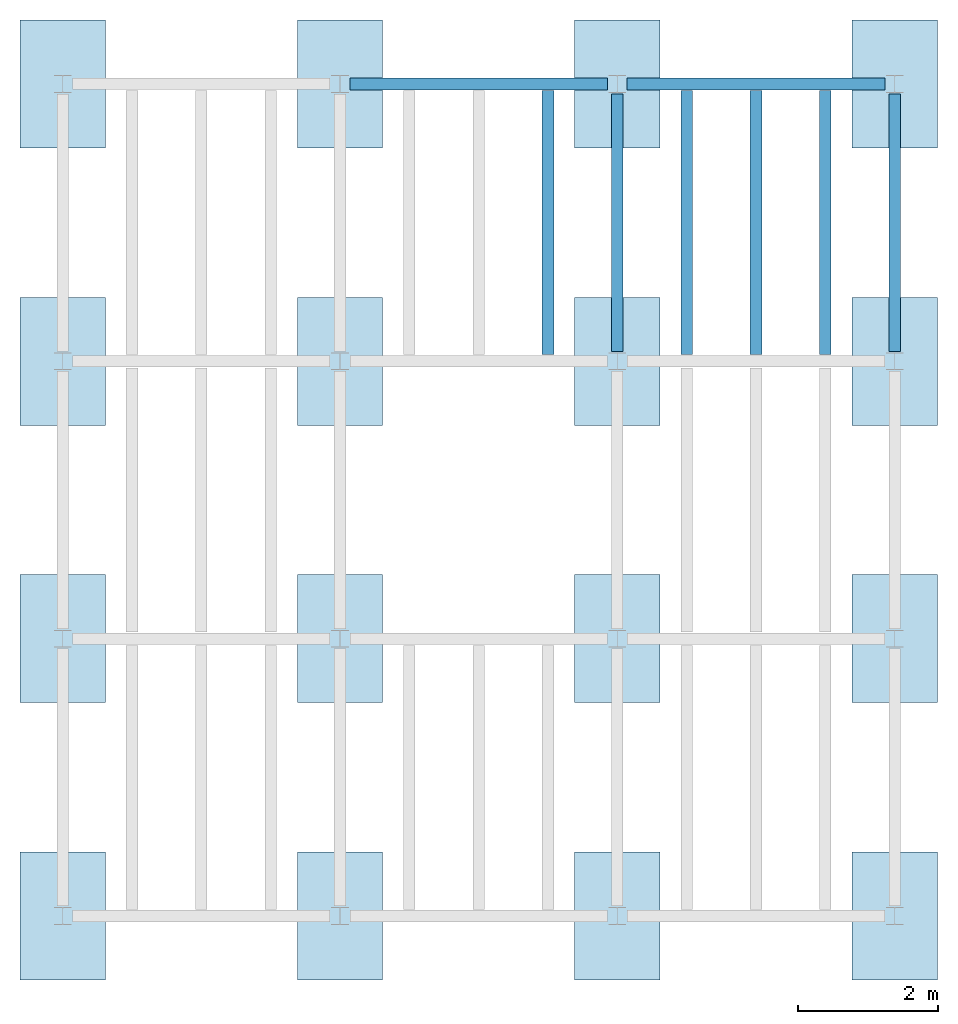
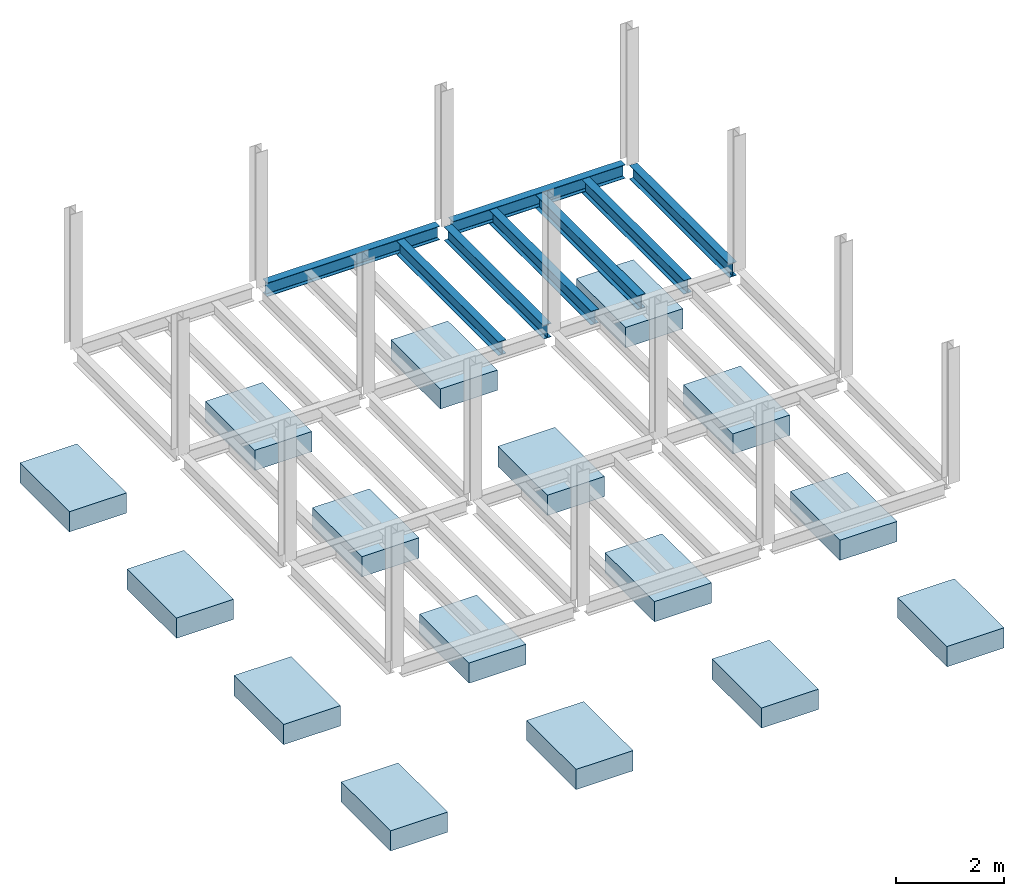
# One storey, part 2 of 2: 16 slabs, 8 beams, 2 elements without a shape of their own.
"""IFC4 building model written with IfcOpenShell, lengths in feet."""

from ifc_helpers import new_model, entity, si_unit, converted_unit, derived_unit, direction, frame, origin, place, context, subcontext, project, spatial, line, arc, indexed_curve, outline, extrude, source, transform, mapped, material, type_object, type_shapes, element, aggregate, save


model = new_model("IFC4")

# Units and contexts
model_context = context("Model", 3, precision=0.0001, world=origin(), true_north=direction((6.123233995736766e-17, 1.0)))
plan_context = context("Plan", 3, precision=0.0001, world=origin(), true_north=direction((6.123233995736766e-17, 1.0)))
body_context = subcontext(model_context, "Body", "Model", "MODEL_VIEW")
ifc_project = project(units=[converted_unit("LENGTHUNIT", "FOOT", entity("IfcLengthMeasure", 0.3048), si_unit("LENGTHUNIT", "METRE"), dimensions=[1, 0, 0, 0, 0, 0, 0]), converted_unit("AREAUNIT", "SQUARE FOOT", entity("IfcAreaMeasure", 0.09290304), si_unit("AREAUNIT", "SQUARE_METRE"), dimensions=[2, 0, 0, 0, 0, 0, 0]), converted_unit("PLANEANGLEUNIT", "DEGREE", entity("IfcPlaneAngleMeasure", 0.017453292519943278), si_unit("PLANEANGLEUNIT", "RADIAN"), dimensions=[0, 0, 0, 0, 0, 0, 0]), converted_unit("VOLUMEUNIT", "CUBIC FOOT", entity("IfcVolumeMeasure", 0.028316846592000004), si_unit("VOLUMEUNIT", "CUBIC_METRE"), dimensions=[3, 0, 0, 0, 0, 0, 0]), si_unit("PRESSUREUNIT", "PASCAL"), derived_unit("MASSDENSITYUNIT", [(si_unit("MASSUNIT", "GRAM", prefix="KILO"), 1), (si_unit("LENGTHUNIT", "METRE"), -3)]), derived_unit("VAPORPERMEABILITYUNIT", [(si_unit("LENGTHUNIT", "METRE"), -1), (si_unit("TIMEUNIT", "SECOND"), 1)]), derived_unit("USERDEFINED", [(si_unit("MASSUNIT", "GRAM", prefix="KILO"), 1), (si_unit("LENGTHUNIT", "METRE"), 3), (si_unit("TIMEUNIT", "SECOND"), -3), (si_unit("ELECTRICCURRENTUNIT", "AMPERE"), -2)]), derived_unit("MODULUSOFELASTICITYUNIT", [(si_unit("MASSUNIT", "GRAM", prefix="KILO"), 1), (si_unit("LENGTHUNIT", "METRE"), -1), (si_unit("TIMEUNIT", "SECOND"), -2)]), derived_unit("THERMALEXPANSIONCOEFFICIENTUNIT", [(si_unit("THERMODYNAMICTEMPERATUREUNIT", "KELVIN"), -1)]), derived_unit("SPECIFICHEATCAPACITYUNIT", [(si_unit("TIMEUNIT", "SECOND"), -2), (si_unit("THERMODYNAMICTEMPERATUREUNIT", "KELVIN"), -1), (si_unit("LENGTHUNIT", "METRE"), 2)]), derived_unit("THERMALCONDUCTANCEUNIT", [(si_unit("MASSUNIT", "GRAM", prefix="KILO"), 1), (si_unit("TIMEUNIT", "SECOND"), -3), (si_unit("THERMODYNAMICTEMPERATUREUNIT", "KELVIN"), -1), (si_unit("LENGTHUNIT", "METRE"), 1)])], contexts=[model_context, plan_context])

# Site, building, storey
site_placement = place(None, origin())
site = spatial("IfcSite", under=ifc_project, at=site_placement, CompositionType="ELEMENT")
building_placement = place(site_placement, origin())
building = spatial("IfcBuilding", under=site, at=building_placement, CompositionType="ELEMENT")
storey_placement = place(building_placement, frame((0.0, 0.0, 9.875000000001839)))
storey = spatial("IfcBuildingStorey", under=building, at=storey_placement, Name="STR 02", CompositionType="ELEMENT", Elevation=9.875000000001839)

# Beams
ifc_material_1 = material(Name="Steel ASTM A992", Category="Metal")
beam_type_1 = type_object("IfcBeamType", Name="W12X26", PredefinedType="JOIST", material=ifc_material_1)
shared_shape_1 = source(origin(), body_context, "Body", "SweptSolid", [
    extrude(outline(indexed_curve([(-0.27041666666666714, -0.47666666666666574), (-0.27041666666666714, -0.5083333333333351), (0.2704166666666669, -0.5083333333333351), (0.2704166666666669, -0.47666666666666574), (0.03458333333333309, -0.47666666666666574), (0.016905663803669493, -0.46934433619632937), (0.009583333333333202, -0.4516666666666659), (0.0095833333333332, 0.45166666666666705), (0.01690566380366948, 0.4693443361963307), (0.03458333333333325, 0.4766666666666671), (0.2704166666666669, 0.4766666666666671), (0.2704166666666669, 0.5083333333333312), (-0.2704166666666655, 0.5083333333333312), (-0.2704166666666655, 0.4766666666666671), (-0.034583333333333514, 0.47666666666666707), (-0.016905663803669865, 0.46934433619633054), (-0.009583333333333737, 0.45166666666666694), (-0.009583333333333735, -0.4516666666666658), (-0.01690566380367013, -0.4693443361963295), (-0.03458333333333368, -0.47666666666666574)], segments=[line(1, 2, 3, 4, 5), arc(5, 6, 7), line(7, 8), arc(8, 9, 10), line(10, 11, 12, 13, 14, 15), arc(15, 16, 17), line(17, 18), arc(18, 19, 20), line(20, 1)], self_intersect=False)), frame((-6.226706036745409, 0.0, 0.0), z_axis=(-1.0, 0.0, 0.0), x_axis=(0.0, -1.0, 0.0)), (0.0, 0.0, -1.0), 12.08333333333333),
])
type_shapes(beam_type_1, [shared_shape_1])
beam_1_placement = place(storey_placement, frame((19.6850393700788, 39.0, -0.5083333333333329)))
element("IfcBeam", 1, at=beam_1_placement, inside=storey, type_object=beam_type_1, material=ifc_material_1, Name="W12X26", ObjectType="W Shapes:W12X26", PredefinedType="JOIST", context=body_context, shape_type="MappedRepresentation", body=[
    mapped(shared_shape_1, transform((0.0, 0.0, 0.0), scale=1.0)),
])
beam_type_2 = type_object("IfcBeamType", Name="W12X26", PredefinedType="JOIST", material=ifc_material_1)
shared_shape_2 = source(origin(), body_context, "Body", "SweptSolid", [
    extrude(outline(indexed_curve([(-0.27041666666666714, -0.47666666666666574), (-0.27041666666666714, -0.5083333333333351), (0.2704166666666669, -0.5083333333333351), (0.2704166666666669, -0.47666666666666574), (0.03458333333333309, -0.47666666666666574), (0.016905663803669493, -0.46934433619632937), (0.009583333333333202, -0.4516666666666659), (0.0095833333333332, 0.45166666666666705), (0.01690566380366948, 0.4693443361963307), (0.03458333333333325, 0.4766666666666671), (0.2704166666666669, 0.4766666666666671), (0.2704166666666669, 0.5083333333333312), (-0.2704166666666655, 0.5083333333333312), (-0.2704166666666655, 0.4766666666666671), (-0.034583333333333514, 0.47666666666666707), (-0.016905663803669865, 0.46934433619633054), (-0.009583333333333737, 0.45166666666666694), (-0.009583333333333735, -0.4516666666666658), (-0.01690566380367013, -0.4693443361963295), (-0.03458333333333368, -0.47666666666666574)], segments=[line(1, 2, 3, 4, 5), arc(5, 6, 7), line(7, 8), arc(8, 9, 10), line(10, 11, 12, 13, 14, 15), arc(15, 16, 17), line(17, 18), arc(18, 19, 20), line(20, 1)], self_intersect=False)), frame((-6.350065616797893, 0.0, 0.0), z_axis=(-1.0, 0.0, 0.0), x_axis=(0.0, -1.0, 0.0)), (0.0, 0.0, -1.0), 12.083333333333323),
])
type_shapes(beam_type_2, [shared_shape_2])
beam_2_placement = place(storey_placement, frame((32.80839895013129, 39.0, -0.5083333333333329)))
element("IfcBeam", 2, at=beam_2_placement, inside=storey, type_object=beam_type_2, material=ifc_material_1, Name="W12X26", ObjectType="W Shapes:W12X26", PredefinedType="JOIST", context=body_context, shape_type="MappedRepresentation", body=[
    mapped(shared_shape_2, transform((0.0, 0.0, 0.0), scale=1.0)),
])
for number, where, z_axis, x_axis, name in (
    (3, (39.0, 32.80839895013111, -0.5083333333333329), (0.0, 0.0, 1.0), (0.0, 1.0, 0.0), "W12X26"),
    (4, (26.0, 32.80839895013115, -0.5083333333333329), (0.0, 0.0, 1.0), (0.0, 1.0, 0.0), "W12X26"),
):
    element("IfcBeam", number, at=place(storey_placement, frame(where, z_axis=z_axis, x_axis=x_axis)), inside=storey, type_object=beam_type_2, material=ifc_material_1, Name=name, ObjectType="W Shapes:W12X26", PredefinedType="JOIST", context=body_context, shape_type="MappedRepresentation", body=[
        mapped(shared_shape_2, transform((0.0, 0.0, 0.0), scale=1.0)),
    ])

# Assembly, beam
assembly_1_placement = place(storey_placement, origin())
assembly_1 = element("IfcElementAssembly", 5, at=assembly_1_placement, inside=storey, Name="Structural Framing System", ObjectType="Structural Beam System:Structural Framing System", AssemblyPlace="NOTDEFINED", PredefinedType="BEAM_GRID")
beam_type_3 = type_object("IfcBeamType", Name="W12X26", PredefinedType="JOIST", material=ifc_material_1)
shared_shape_3 = source(origin(), body_context, "Body", "SweptSolid", [
    extrude(outline(indexed_curve([(-0.27041666666666714, -0.47666666666666574), (-0.27041666666666714, -0.5083333333333351), (0.2704166666666669, -0.5083333333333351), (0.2704166666666669, -0.47666666666666574), (0.03458333333333309, -0.47666666666666574), (0.016905663803669493, -0.46934433619632937), (0.009583333333333202, -0.4516666666666659), (0.0095833333333332, 0.45166666666666705), (0.01690566380366948, 0.4693443361963307), (0.03458333333333325, 0.4766666666666671), (0.2704166666666669, 0.4766666666666671), (0.2704166666666669, 0.5083333333333312), (-0.2704166666666655, 0.5083333333333312), (-0.2704166666666655, 0.4766666666666671), (-0.034583333333333514, 0.47666666666666707), (-0.016905663803669865, 0.46934433619633054), (-0.009583333333333737, 0.45166666666666694), (-0.009583333333333735, -0.4516666666666658), (-0.01690566380367013, -0.4693443361963295), (-0.03458333333333368, -0.47666666666666574)], segments=[line(1, 2, 3, 4, 5), arc(5, 6, 7), line(7, 8), arc(8, 9, 10), line(10, 11, 12, 13, 14, 15), arc(15, 16, 17), line(17, 18), arc(18, 19, 20), line(20, 1)], self_intersect=False)), frame((-6.187916666666566, 0.0, 0.0), z_axis=(-1.0, 0.0, 0.0), x_axis=(0.0, -1.0, 0.0)), (0.0, 0.0, -1.0), 12.375833333333075),
])
type_shapes(beam_type_3, [shared_shape_3])
beam_3_placement = place(assembly_1_placement, frame((22.750000000000142, 32.499999999999616, -0.5083333333333329), z_axis=(0.0, 0.0, 1.0), x_axis=(0.0, 1.0, 0.0)))
beam_3 = element("IfcBeam", 6, at=beam_3_placement, type_object=beam_type_3, material=ifc_material_1, Name="W12X26", ObjectType="W Shapes:W12X26", PredefinedType="JOIST", context=body_context, shape_type="MappedRepresentation", body=[
    mapped(shared_shape_3, transform((0.0, 0.0, 0.0), scale=1.0)),
])
aggregate(assembly_1, [beam_3])

# Assembly, beams
assembly_2_placement = place(storey_placement, origin())
assembly_2 = element("IfcElementAssembly", 7, at=assembly_2_placement, inside=storey, Name="Structural Framing System", ObjectType="Structural Beam System:Structural Framing System", AssemblyPlace="NOTDEFINED", PredefinedType="BEAM_GRID")
beam_4_placement = place(assembly_2_placement, frame((29.250000000000142, 32.49999999999973, -0.5083333333333329), z_axis=(0.0, 0.0, 1.0), x_axis=(0.0, 1.0, 0.0)))
beam_4 = element("IfcBeam", 8, at=beam_4_placement, type_object=beam_type_3, material=ifc_material_1, Name="W12X26", ObjectType="W Shapes:W12X26", PredefinedType="JOIST", context=body_context, shape_type="MappedRepresentation", body=[
    mapped(shared_shape_3, transform((0.0, 0.0, 0.0), scale=1.0)),
])
beam_5_placement = place(assembly_2_placement, frame((32.50000000000014, 32.499999999999716, -0.5083333333333329), z_axis=(0.0, 0.0, 1.0), x_axis=(0.0, 1.0, 0.0)))
beam_5 = element("IfcBeam", 9, at=beam_5_placement, type_object=beam_type_3, material=ifc_material_1, Name="W12X26", ObjectType="W Shapes:W12X26", PredefinedType="JOIST", context=body_context, shape_type="MappedRepresentation", body=[
    mapped(shared_shape_3, transform((0.0, 0.0, 0.0), scale=1.0)),
])
beam_6_placement = place(assembly_2_placement, frame((35.75000000000014, 32.49999999999971, -0.5083333333333329), z_axis=(0.0, 0.0, 1.0), x_axis=(0.0, 1.0, 0.0)))
beam_6 = element("IfcBeam", 10, at=beam_6_placement, type_object=beam_type_3, material=ifc_material_1, Name="W12X26", ObjectType="W Shapes:W12X26", PredefinedType="JOIST", context=body_context, shape_type="MappedRepresentation", body=[
    mapped(shared_shape_3, transform((0.0, 0.0, 0.0), scale=1.0)),
])
aggregate(assembly_2, [beam_4, beam_5, beam_6])

# Slabs
ifc_material_2 = material(Category="DIVISION 03 - CONCRETE")
slab_type = type_object("IfcSlabType", PredefinedType="BASESLAB", material=ifc_material_2)
slab_1_placement = place(storey_placement, origin())
element("IfcSlab", 11, at=slab_1_placement, inside=storey, type_object=slab_type, PredefinedType="BASESLAB", context=body_context, shape_type="SweptSolid", body=[
    extrude(outline(indexed_curve([(-1.9999999999999993, -3.0), (1.9999999999999998, -3.0), (1.9999999999999993, 3.0), (-2.0000000000000004, 3.0), (-1.9999999999999993, -3.0)], self_intersect=False)), frame((0.0, 0.0, -11.375000000001839)), (0.0, 0.0, 1.0), 1.5),
])
slab_2_placement = place(storey_placement, frame((0.0, 0.0, -9.875000000001839)))
element("IfcSlab", 12, at=slab_2_placement, inside=storey, type_object=slab_type, PredefinedType="BASESLAB", context=body_context, shape_type="SweptSolid", body=[
    extrude(outline(indexed_curve([(-1.9999999999999964, -3.0), (2.0000000000000036, -3.0), (2.0000000000000036, 3.0), (-1.9999999999999964, 3.0), (-1.9999999999999964, -3.0)], self_intersect=False)), frame((39.0, 13.0, -1.5)), (0.0, 0.0, 1.0), 1.5),
])
slab_3_placement = place(storey_placement, frame((0.0, 0.0, -9.875000000001839)))
element("IfcSlab", 13, at=slab_3_placement, inside=storey, type_object=slab_type, PredefinedType="BASESLAB", context=body_context, shape_type="SweptSolid", body=[
    extrude(outline(indexed_curve([(-1.9999999999999964, -3.0), (2.0000000000000036, -3.0), (2.0000000000000036, 3.0), (-1.9999999999999964, 3.0), (-1.9999999999999964, -3.0)], self_intersect=False)), frame((39.0, 26.0, -1.5)), (0.0, 0.0, 1.0), 1.5),
])
slab_4_placement = place(storey_placement, frame((0.0, 0.0, -9.875000000001839)))
element("IfcSlab", 14, at=slab_4_placement, inside=storey, type_object=slab_type, PredefinedType="BASESLAB", context=body_context, shape_type="SweptSolid", body=[
    extrude(outline(indexed_curve([(-2.0000000000000036, -3.0), (1.9999999999999964, -3.0), (1.9999999999999964, 3.0), (-2.0000000000000036, 3.0), (-2.0000000000000036, -3.0)], self_intersect=False)), frame((39.0, 39.0, -1.5)), (0.0, 0.0, 1.0), 1.5),
])
slab_5_placement = place(storey_placement, frame((0.0, 0.0, -9.875000000001839)))
element("IfcSlab", 15, at=slab_5_placement, inside=storey, type_object=slab_type, PredefinedType="BASESLAB", context=body_context, shape_type="SweptSolid", body=[
    extrude(outline(indexed_curve([(-1.9999999999999971, -3.0), (2.000000000000003, -3.0), (2.0000000000000044, 3.0), (-1.9999999999999958, 3.0), (-1.9999999999999971, -3.0)], self_intersect=False)), frame((39.0, 0.0, -1.5)), (0.0, 0.0, 1.0), 1.5),
])
slab_6_placement = place(storey_placement, frame((0.0, 0.0, -9.875000000001839)))
element("IfcSlab", 16, at=slab_6_placement, inside=storey, type_object=slab_type, PredefinedType="BASESLAB", context=body_context, shape_type="SweptSolid", body=[
    extrude(outline(indexed_curve([(-1.9999999999999971, -3.0), (2.000000000000003, -3.0), (2.000000000000001, 3.0), (-1.9999999999999958, 3.0), (-1.9999999999999971, -3.0)], self_intersect=False)), frame((26.0, 0.0, -1.5)), (0.0, 0.0, 1.0), 1.5),
])
slab_7_placement = place(storey_placement, frame((0.0, 0.0, -9.875000000001839)))
element("IfcSlab", 17, at=slab_7_placement, inside=storey, type_object=slab_type, PredefinedType="BASESLAB", context=body_context, shape_type="SweptSolid", body=[
    extrude(outline(indexed_curve([(-1.9999999999999971, -3.0), (2.0000000000000013, -3.0), (2.000000000000001, 3.0), (-1.9999999999999993, 3.0), (-1.9999999999999971, -3.0)], self_intersect=False)), frame((13.0, 0.0, -1.5)), (0.0, 0.0, 1.0), 1.5),
])
slab_8_placement = place(storey_placement, frame((0.0, 0.0, -9.875000000001839)))
element("IfcSlab", 18, at=slab_8_placement, inside=storey, type_object=slab_type, PredefinedType="BASESLAB", context=body_context, shape_type="SweptSolid", body=[
    extrude(outline(indexed_curve([(-1.9999999999999987, -3.0), (2.0000000000000004, -3.0), (1.9999999999999987, 3.0), (-2.000000000000001, 3.0), (-1.9999999999999987, -3.0)], self_intersect=False)), frame((0.0, 13.0, -1.5)), (0.0, 0.0, 1.0), 1.5),
])
slab_9_placement = place(storey_placement, frame((0.0, 0.0, -9.875000000001839)))
element("IfcSlab", 19, at=slab_9_placement, inside=storey, type_object=slab_type, PredefinedType="BASESLAB", context=body_context, shape_type="SweptSolid", body=[
    extrude(outline(indexed_curve([(-2.0, -3.0), (1.9999999999999982, -3.0), (1.9999999999999964, 3.0), (-2.0000000000000036, 3.0), (-2.0, -3.0)], self_intersect=False)), frame((13.0, 13.0, -1.5)), (0.0, 0.0, 1.0), 1.5),
])
slab_10_placement = place(storey_placement, frame((0.0, 0.0, -9.875000000001839)))
element("IfcSlab", 20, at=slab_10_placement, inside=storey, type_object=slab_type, PredefinedType="BASESLAB", context=body_context, shape_type="SweptSolid", body=[
    extrude(outline(indexed_curve([(-2.0, -3.0), (2.0, -3.0), (1.9999999999999964, 3.0), (-2.0, 3.0), (-2.0, -3.0)], self_intersect=False)), frame((26.0, 13.0, -1.5)), (0.0, 0.0, 1.0), 1.5),
])
slab_11_placement = place(storey_placement, frame((0.0, 0.0, -9.875000000001839)))
element("IfcSlab", 21, at=slab_11_placement, inside=storey, type_object=slab_type, PredefinedType="BASESLAB", context=body_context, shape_type="SweptSolid", body=[
    extrude(outline(indexed_curve([(-1.9999999999999964, -3.0), (2.0000000000000036, -3.0), (2.0, 3.0), (-1.9999999999999964, 3.0), (-1.9999999999999964, -3.0)], self_intersect=False)), frame((26.0, 26.0, -1.5)), (0.0, 0.0, 1.0), 1.5),
])
slab_12_placement = place(storey_placement, frame((0.0, 0.0, -9.875000000001839)))
element("IfcSlab", 22, at=slab_12_placement, inside=storey, type_object=slab_type, PredefinedType="BASESLAB", context=body_context, shape_type="SweptSolid", body=[
    extrude(outline(indexed_curve([(-1.9999999999999982, -3.0), (2.0, -3.0), (1.9999999999999982, 3.0), (-2.0000000000000018, 3.0), (-1.9999999999999982, -3.0)], self_intersect=False)), frame((13.0, 26.0, -1.5)), (0.0, 0.0, 1.0), 1.5),
])
slab_13_placement = place(storey_placement, frame((0.0, 0.0, -9.875000000001839)))
element("IfcSlab", 23, at=slab_13_placement, inside=storey, type_object=slab_type, PredefinedType="BASESLAB", context=body_context, shape_type="SweptSolid", body=[
    extrude(outline(indexed_curve([(-1.9999999999999982, -3.0), (2.000000000000001, -3.0), (1.9999999999999982, 3.0), (-2.000000000000001, 3.0), (-1.9999999999999982, -3.0)], self_intersect=False)), frame((0.0, 26.0, -1.5)), (0.0, 0.0, 1.0), 1.5),
])
slab_14_placement = place(storey_placement, frame((0.0, 0.0, -9.875000000001839)))
element("IfcSlab", 24, at=slab_14_placement, inside=storey, type_object=slab_type, PredefinedType="BASESLAB", context=body_context, shape_type="SweptSolid", body=[
    extrude(outline(indexed_curve([(-1.9999999999999982, -3.0), (2.000000000000001, -3.0), (1.9999999999999987, 3.0), (-2.000000000000001, 3.0), (-1.9999999999999982, -3.0)], self_intersect=False)), frame((0.0, 39.0, -1.5)), (0.0, 0.0, 1.0), 1.5),
])
slab_15_placement = place(storey_placement, frame((0.0, 0.0, -9.875000000001839)))
element("IfcSlab", 25, at=slab_15_placement, inside=storey, type_object=slab_type, PredefinedType="BASESLAB", context=body_context, shape_type="SweptSolid", body=[
    extrude(outline(indexed_curve([(-1.9999999999999982, -3.0), (2.0, -3.0), (1.9999999999999982, 3.0), (-2.0000000000000018, 3.0), (-1.9999999999999982, -3.0)], self_intersect=False)), frame((13.0, 39.0, -1.5)), (0.0, 0.0, 1.0), 1.5),
])
slab_16_placement = place(storey_placement, frame((0.0, 0.0, -9.875000000001839)))
element("IfcSlab", 26, at=slab_16_placement, inside=storey, type_object=slab_type, PredefinedType="BASESLAB", context=body_context, shape_type="SweptSolid", body=[
    extrude(outline(indexed_curve([(-2.0, -3.0), (2.0, -3.0), (1.9999999999999964, 3.0), (-2.0, 3.0), (-2.0, -3.0)], self_intersect=False)), frame((26.0, 39.0, -1.5)), (0.0, 0.0, 1.0), 1.5),
])

save(model, "model.ifc")
